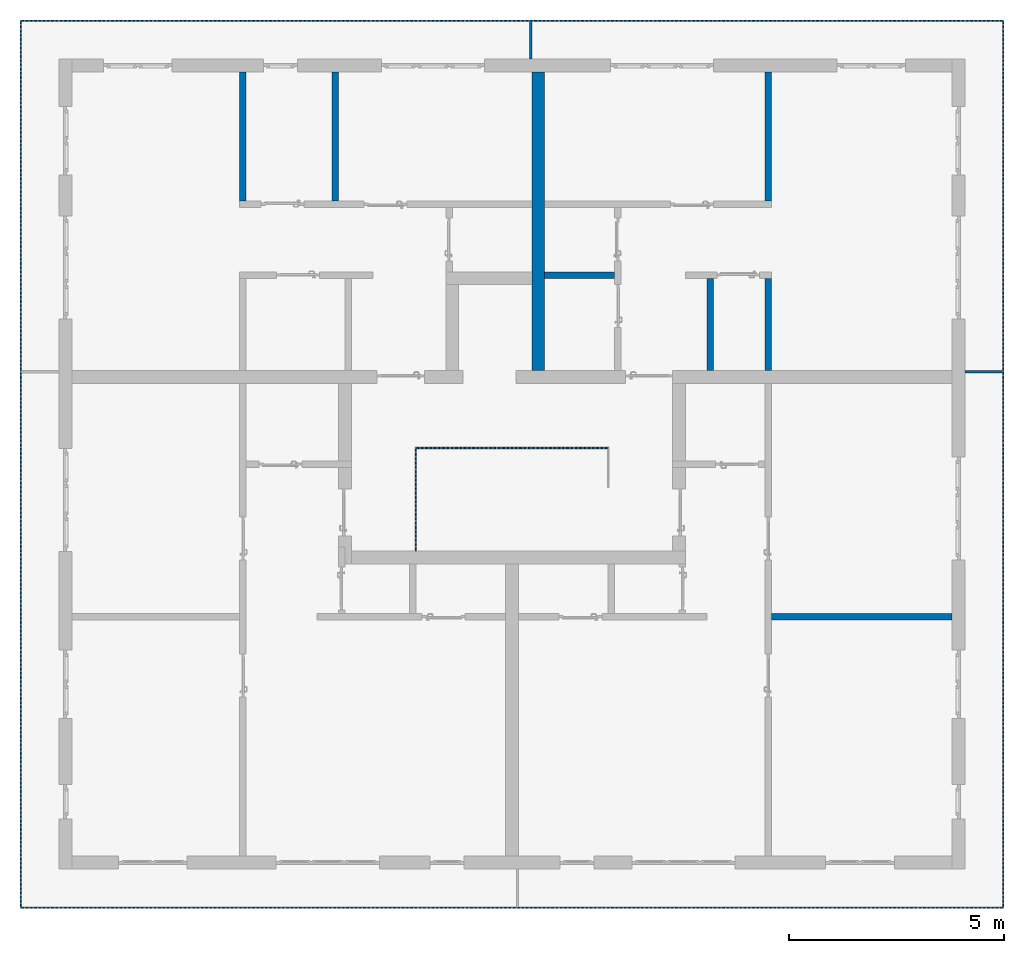
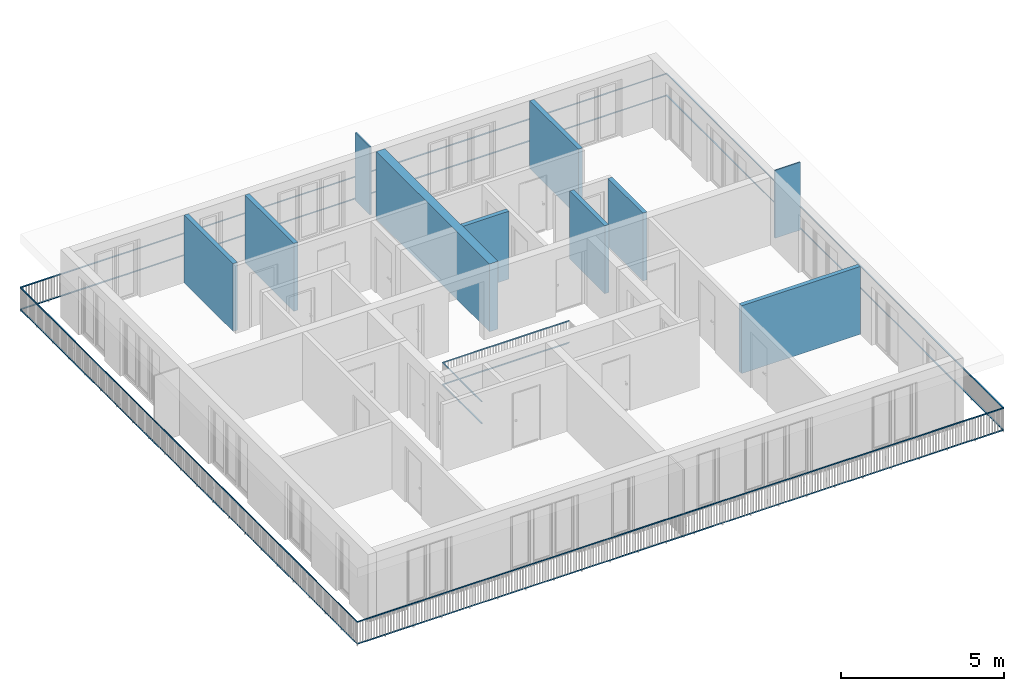
# One storey, part 31 of 54: 12 building element parts, 10 walls, 2 elements without a shape of their own.
"""IFC4 building model written with IfcOpenShell, lengths in metres."""

from ifc_helpers import new_model, entity, si_unit, converted_unit, derived_unit, direction, frame, origin_with_axes, place, context, subcontext, project, spatial, polygons, material, type_object, element, aggregate, save


model = new_model("IFC4")

# Units and contexts
model_context = context("Model", 3, precision=1e-05, world=origin_with_axes(), true_north=direction((0.0, 1.0)))
body_context = subcontext(model_context, "Body", "Model", "MODEL_VIEW")
ifc_project = project(units=[si_unit("LENGTHUNIT", "METRE"), si_unit("AREAUNIT", "SQUARE_METRE"), si_unit("VOLUMEUNIT", "CUBIC_METRE"), converted_unit("PLANEANGLEUNIT", "DEGREE", entity("IfcPlaneAngleMeasure", 0.0174532925199), si_unit("PLANEANGLEUNIT", "RADIAN"), dimensions=[0, 0, 0, 0, 0, 0, 0]), converted_unit("TIMEUNIT", "Year", entity("IfcTimeMeasure", 31556926.0), si_unit("TIMEUNIT", "SECOND"), dimensions=[0, 0, 1, 0, 0, 0, 0]), si_unit("MASSUNIT", "GRAM", prefix="KILO"), si_unit("THERMODYNAMICTEMPERATUREUNIT", "DEGREE_CELSIUS"), si_unit("LUMINOUSINTENSITYUNIT", "LUMEN"), si_unit("ENERGYUNIT", "JOULE", prefix="MEGA"), derived_unit("THERMALCONDUCTANCEUNIT", [(si_unit("POWERUNIT", "WATT"), 1), (si_unit("LENGTHUNIT", "METRE"), -1), (si_unit("THERMODYNAMICTEMPERATUREUNIT", "KELVIN"), -1)]), derived_unit("SPECIFICHEATCAPACITYUNIT", [(si_unit("ENERGYUNIT", "JOULE"), 1), (si_unit("MASSUNIT", "GRAM", prefix="KILO"), -1), (si_unit("THERMODYNAMICTEMPERATUREUNIT", "KELVIN"), -1)]), derived_unit("MASSDENSITYUNIT", [(si_unit("MASSUNIT", "GRAM", prefix="KILO"), 1), (si_unit("VOLUMEUNIT", "CUBIC_METRE"), -1)])], contexts=[model_context])

# Site, building, storey
site_placement = place(None, origin_with_axes())
site = spatial("IfcSite", under=ifc_project, at=site_placement, CompositionType="ELEMENT")
building_placement = place(site_placement, origin_with_axes())
building = spatial("IfcBuilding", under=site, at=building_placement, CompositionType="ELEMENT")
storey_placement = place(building_placement, frame((0.0, 0.0, 9.18), z_axis=(0.0, 0.0, 1.0), x_axis=(1.0, 0.0, 0.0)))
storey = spatial("IfcBuildingStorey", under=building, at=storey_placement, Name="3. Geschoss", CompositionType="ELEMENT", Elevation=9.18)

# Walls
ifc_material_1 = material()
wall_type_1 = type_object("IfcWallType", Name="300", PredefinedType="NOTDEFINED")
wall_1_placement = place(storey_placement, frame((-0.742199380397, 1.37118776896, 0.0), z_axis=(0.0, 0.0, 1.0), x_axis=(0.0, 1.0, 0.0)))
element("IfcWall", 1, at=wall_1_placement, inside=storey, type_object=wall_type_1, material=ifc_material_1, Name="Wand-001", PredefinedType="NOTDEFINED", context=body_context, shape_type="Tessellation", body=[
    polygons([(7.25, 0.0, 0.0), (7.25, 0.0, 2.54), (7.25, -0.3, 2.54), (7.25, -0.3, 0.0), (0.3, 0.0, 0.0), (0.3, 0.0, 2.54), (0.3, -0.3, 2.54), (0.3, -0.3, 0.0)], [[[1, 2, 3, 4]], [[5, 6, 2, 1]], [[6, 7, 3, 2]], [[4, 3, 7, 8]], [[8, 5, 1, 4]], [[8, 7, 6, 5]]], closed=True),
])
wall_type_2 = type_object("IfcWallType", Name="150", PredefinedType="NOTDEFINED")
wall_2_placement = place(storey_placement, frame((-7.5421993804, 5.47118776896, 0.0), z_axis=(0.0, 0.0, 1.0), x_axis=(0.0, 1.0, 0.0)))
element("IfcWall", 2, at=wall_2_placement, inside=storey, type_object=wall_type_2, material=ifc_material_1, Name="Wand-002", PredefinedType="NOTDEFINED", context=body_context, shape_type="Tessellation", body=[
    polygons([(3.15, 0.0, 0.0), (3.15, 0.0, 2.54), (3.15, -0.15, 2.54), (3.15, -0.15, 0.0), (0.15, 0.0, 0.0), (0.15, 0.0, 2.54), (0.15, -0.15, 2.54), (0.15, -0.15, 0.0)], [[[1, 2, 3, 4]], [[5, 6, 2, 1]], [[6, 7, 3, 2]], [[4, 3, 7, 8]], [[5, 1, 4, 8]], [[8, 7, 6, 5]]], closed=True),
])
wall_3_placement = place(storey_placement, frame((3.3378006196, 1.37118776896, 0.0), z_axis=(0.0, 0.0, 1.0), x_axis=(0.0, 1.0, 0.0)))
element("IfcWall", 3, at=wall_3_placement, inside=storey, type_object=wall_type_2, material=ifc_material_1, Name="Wand-002", PredefinedType="NOTDEFINED", context=body_context, shape_type="Tessellation", body=[
    polygons([(2.45, 0.0, 0.0), (2.45, 0.0, 2.54), (2.45, -0.15, 2.54), (2.45, -0.15, 0.0), (0.3, 0.0, 0.0), (0.3, 0.0, 2.54), (0.3, -0.15, 2.54), (0.3, -0.15, 0.0)], [[[1, 2, 3, 4]], [[5, 6, 2, 1]], [[6, 7, 3, 2]], [[4, 3, 7, 8]], [[5, 1, 4, 8]], [[8, 7, 6, 5]]], closed=True),
])
wall_4_placement = place(storey_placement, frame((1.3378006196, 3.97118776896, 0.0), z_axis=(0.0, 0.0, 1.0), x_axis=(-1.0, 0.0, 0.0)))
element("IfcWall", 4, at=wall_4_placement, inside=storey, type_object=wall_type_2, material=ifc_material_1, Name="Wand-002", PredefinedType="NOTDEFINED", context=body_context, shape_type="Tessellation", body=[
    polygons([(1.78, 0.0, 0.0), (1.78, 0.0, 2.54), (0.15, 0.0, 2.54), (0.15, 0.0, 0.0), (1.78, 0.15, 0.0), (1.78, 0.15, 2.54), (0.15, 0.15, 2.54), (0.15, 0.15, 0.0)], [[[1, 2, 3, 4]], [[5, 6, 2, 1]], [[6, 7, 3, 2]], [[4, 3, 7, 8]], [[8, 5, 1, 4]], [[8, 7, 6, 5]]], closed=True),
])
for number, where, z_axis, x_axis, name in (
    (5, (-5.3921993804, 5.47118776896, 0.0), (0.0, 0.0, 1.0), (0.0, 1.0, 0.0), "Wand-002"),
    (6, (4.6878006196, 5.47118776896, 0.0), (0.0, 0.0, 1.0), (0.0, 1.0, 0.0), "Wand-002"),
):
    element("IfcWall", number, at=place(storey_placement, frame(where, z_axis=z_axis, x_axis=x_axis)), inside=storey, type_object=wall_type_2, material=ifc_material_1, Name=name, PredefinedType="NOTDEFINED", context=body_context, shape_type="Tessellation", body=[
        polygons([(3.15, 0.0, 0.0), (3.15, 0.0, 2.54), (3.15, -0.15, 2.54), (3.15, -0.15, 0.0), (0.15, 0.0, 0.0), (0.15, 0.0, 2.54), (0.15, -0.15, 2.54), (0.15, -0.15, 0.0)], [[[1, 2, 3, 4]], [[5, 6, 2, 1]], [[6, 7, 3, 2]], [[4, 3, 7, 8]], [[5, 1, 4, 8]], [[8, 7, 6, 5]]], closed=True),
    ])
wall_5_placement = place(storey_placement, frame((9.3378006196, -4.12881223104, 0.0), z_axis=(0.0, 0.0, 1.0), x_axis=(-1.0, 0.0, 0.0)))
element("IfcWall", 7, at=wall_5_placement, inside=storey, type_object=wall_type_2, material=ifc_material_1, Name="Wand-004", PredefinedType="NOTDEFINED", context=body_context, shape_type="Tessellation", body=[
    polygons([(4.5, -0.15, 0.0), (4.5, -0.15, 2.54), (0.3, -0.15, 2.54), (0.3, -0.15, 0.0), (4.5, 0.0, 0.0), (4.5, 0.0, 2.54), (0.3, 0.0, 2.54), (0.3, 0.0, 0.0)], [[[1, 2, 3, 4]], [[5, 6, 2, 1]], [[6, 7, 3, 2]], [[4, 3, 7, 8]], [[8, 5, 1, 4]], [[8, 7, 6, 5]]], closed=True),
])
wall_6_placement = place(storey_placement, frame((4.6878006196, 1.37118776896, 0.0), z_axis=(0.0, 0.0, 1.0), x_axis=(0.0, 1.0, 0.0)))
element("IfcWall", 8, at=wall_6_placement, inside=storey, type_object=wall_type_2, material=ifc_material_1, Name="Wand-002", PredefinedType="NOTDEFINED", context=body_context, shape_type="Tessellation", body=[
    polygons([(2.45, 0.0, 0.0), (2.45, 0.0, 2.54), (2.45, -0.15, 2.54), (2.45, -0.15, 0.0), (0.3, 0.0, 0.0), (0.3, 0.0, 2.54), (0.3, -0.15, 2.54), (0.3, -0.15, 0.0)], [[[1, 2, 3, 4]], [[5, 6, 2, 1]], [[6, 7, 3, 2]], [[4, 3, 7, 8]], [[5, 1, 4, 8]], [[8, 7, 6, 5]]], closed=True),
])
ifc_material_2 = material()
wall_type_3 = type_object("IfcWallType", Name="50", PredefinedType="NOTDEFINED")
wall_7_placement = place(storey_placement, frame((9.0378006196, 1.67118776896, 0.0), z_axis=(0.0, 0.0, 1.0), x_axis=(1.0, 0.0, 0.0)))
element("IfcWall", 9, at=wall_7_placement, inside=storey, type_object=wall_type_3, material=ifc_material_2, Name="Wand-003", PredefinedType="NOTDEFINED", context=body_context, shape_type="Tessellation", body=[
    polygons([(0.3, 0.0, 2.54), (1.2, 0.0, 2.54), (1.2, 0.0, 0.0), (0.3, 0.0, 0.0), (1.2, -0.05, 2.54), (0.3, -0.05, 2.54), (1.2, -0.05, 0.0), (0.3, -0.05, 0.0)], [[[1, 2, 3, 4]], [[5, 2, 1, 6]], [[2, 5, 7, 3]], [[4, 3, 7, 8]], [[6, 1, 4, 8]], [[5, 6, 8, 7]]], closed=True),
])
wall_8_placement = place(storey_placement, frame((-0.742199380397, 9.82118776896, 0.0), z_axis=(0.0, 0.0, 1.0), x_axis=(0.0, -1.0, 0.0)))
element("IfcWall", 10, at=wall_8_placement, inside=storey, type_object=wall_type_3, material=ifc_material_2, Name="Wand-003", PredefinedType="NOTDEFINED", context=body_context, shape_type="Tessellation", body=[
    polygons([(0.0, -0.05, 2.54), (0.0, 0.0, 2.54), (0.0, 0.0, 0.0), (0.0, -0.05, 0.0), (0.9, 0.0, 2.54), (0.9, -0.05, 2.54), (0.9, 0.0, 0.0), (0.9, -0.05, 0.0)], [[[1, 2, 3, 4]], [[5, 2, 1, 6]], [[2, 5, 7, 3]], [[7, 8, 4, 3]], [[6, 1, 4, 8]], [[5, 6, 8, 7]]], closed=True),
])

# Space
space_1_placement = place(storey_placement, frame((-3.4421993804, -2.52881223104, 0.0), z_axis=(0.0, 0.0, 1.0), x_axis=(1.0, 0.0, 0.0)))
space_1 = spatial("IfcSpace", under=storey, at=space_1_placement, CompositionType="ELEMENT", PredefinedType="INTERNAL")

# Railing, building element parts
railing_type = type_object("IfcRailingType", PredefinedType="NOTDEFINED")
railing_1_placement = place(space_1_placement, frame((0.0, 1.5, 0.0), z_axis=(0.0, 0.0, 1.0), x_axis=(1.0, 0.0, 0.0)))
railing_1 = element("IfcRailing", 11, at=railing_1_placement, inside=space_1, type_object=railing_type, PredefinedType="NOTDEFINED")
ifc_material_3 = material()
building_element_part_1_placement = place(railing_1_placement, origin_with_axes())
building_element_part_1 = element("IfcBuildingElementPart", 12, at=building_element_part_1_placement, material=ifc_material_3, PredefinedType="NOTDEFINED", context=body_context, shape_type="Tessellation", body=[
    polygons([(0.0125, -1.5, 0.9), (0.0125, -1.5, 0.875), (0.0125, 0.8875, 0.875), (0.0125, 0.8875, 0.9), (-0.0125, -1.5, 0.9), (-0.0125, -1.5, 0.875), (-0.0125, 0.9125, 0.875), (-0.0125, 0.9125, 0.9)], [[[1, 2, 3, 4]], [[1, 5, 6, 2]], [[2, 6, 7, 3]], [[4, 3, 7, 8]], [[5, 1, 4, 8]], [[6, 5, 8, 7]]], closed=True),
])
building_element_part_2_placement = place(railing_1_placement, origin_with_axes())
building_element_part_2 = element("IfcBuildingElementPart", 13, at=building_element_part_2_placement, material=ifc_material_3, PredefinedType="NOTDEFINED", context=body_context, shape_type="Tessellation", body=[
    polygons([(0.0125, -1.5, 0.0825), (0.0125, -1.5, 0.0575), (0.0125, 0.8875, 0.0575), (0.0125, 0.8875, 0.0825), (-0.0125, -1.5, 0.0825), (-0.0125, -1.5, 0.0575), (-0.0125, 0.9125, 0.0575), (-0.0125, 0.9125, 0.0825)], [[[1, 2, 3, 4]], [[1, 5, 6, 2]], [[2, 6, 7, 3]], [[4, 3, 7, 8]], [[5, 1, 4, 8]], [[6, 5, 8, 7]]], closed=True),
])
building_element_part_3_placement = place(railing_1_placement, origin_with_axes())
building_element_part_3 = element("IfcBuildingElementPart", 14, at=building_element_part_3_placement, material=ifc_material_3, PredefinedType="NOTDEFINED", context=body_context, shape_type="Tessellation", body=[
    polygons([(0.0125, 0.8875, 0.9), (0.0125, 0.8875, 0.875), (4.4675, 0.8875, 0.875), (4.4675, 0.8875, 0.9), (-0.0125, 0.9125, 0.9), (-0.0125, 0.9125, 0.875), (4.4925, 0.9125, 0.875), (4.4925, 0.9125, 0.9)], [[[1, 2, 3, 4]], [[1, 5, 6, 2]], [[2, 6, 7, 3]], [[4, 3, 7, 8]], [[5, 1, 4, 8]], [[6, 5, 8, 7]]], closed=True),
])
building_element_part_4_placement = place(railing_1_placement, origin_with_axes())
building_element_part_4 = element("IfcBuildingElementPart", 15, at=building_element_part_4_placement, material=ifc_material_3, PredefinedType="NOTDEFINED", context=body_context, shape_type="Tessellation", body=[
    polygons([(0.0125, 0.8875, 0.0825), (0.0125, 0.8875, 0.0575), (4.4675, 0.8875, 0.0575), (4.4675, 0.8875, 0.0825), (-0.0125, 0.9125, 0.0825), (-0.0125, 0.9125, 0.0575), (4.4925, 0.9125, 0.0575), (4.4925, 0.9125, 0.0825)], [[[1, 2, 3, 4]], [[1, 5, 6, 2]], [[2, 6, 7, 3]], [[4, 3, 7, 8]], [[5, 1, 4, 8]], [[6, 5, 8, 7]]], closed=True),
])
aggregate(railing_1, [building_element_part_1, building_element_part_2, building_element_part_3, building_element_part_4])

# Space
space_2_placement = place(storey_placement, frame((10.2378006196, 9.82118769833, 0.0), z_axis=(0.0, 0.0, 1.0), x_axis=(-1.0, 0.0, 0.0)))
space_2 = spatial("IfcSpace", under=storey, at=space_2_placement, CompositionType="ELEMENT", PredefinedType="EXTERNAL")

# Railing, building element parts
railing_2_placement = place(space_2_placement, frame((0.0, -7.06315681498e-08, 0.0), z_axis=(0.0, 0.0, 1.0), x_axis=(-1.0, 0.0, 0.0)))
railing_2 = element("IfcRailing", 16, at=railing_2_placement, inside=space_2, type_object=railing_type, PredefinedType="NOTDEFINED")
building_element_part_5_placement = place(railing_2_placement, origin_with_axes())
building_element_part_5 = element("IfcBuildingElementPart", 17, at=building_element_part_5_placement, material=ifc_material_3, PredefinedType="NOTDEFINED", context=body_context, shape_type="Tessellation", body=[
    polygons([(0.0, 0.0125, 0.9), (0.0, 0.0125, 0.875), (-22.8925, 0.0125, 0.875), (-22.8925, 0.0125, 0.9), (0.0, -0.0125, 0.9), (0.0, -0.0125, 0.875), (-22.8675, -0.0125, 0.875), (-22.8675, -0.0125, 0.9)], [[[1, 2, 3, 4]], [[1, 5, 6, 2]], [[2, 6, 7, 3]], [[4, 3, 7, 8]], [[5, 1, 4, 8]], [[6, 5, 8, 7]]], closed=True),
])
building_element_part_6_placement = place(railing_2_placement, origin_with_axes())
building_element_part_6 = element("IfcBuildingElementPart", 18, at=building_element_part_6_placement, material=ifc_material_3, PredefinedType="NOTDEFINED", context=body_context, shape_type="Tessellation", body=[
    polygons([(0.0, 0.0125, 0.0825), (0.0, 0.0125, 0.0575), (-22.8925, 0.0125, 0.0575), (-22.8925, 0.0125, 0.0825), (0.0, -0.0125, 0.0825), (0.0, -0.0125, 0.0575), (-22.8675, -0.0125, 0.0575), (-22.8675, -0.0125, 0.0825)], [[[1, 2, 3, 4]], [[1, 5, 6, 2]], [[2, 6, 7, 3]], [[4, 3, 7, 8]], [[5, 1, 4, 8]], [[6, 5, 8, 7]]], closed=True),
])
building_element_part_7_placement = place(railing_2_placement, origin_with_axes())
building_element_part_7 = element("IfcBuildingElementPart", 19, at=building_element_part_7_placement, material=ifc_material_3, PredefinedType="NOTDEFINED", context=body_context, shape_type="Tessellation", body=[
    polygons([(-22.8925, 0.0125, 0.9), (-22.8925, 0.0125, 0.875), (-22.8925, -20.6625, 0.875), (-22.8925, -20.6625, 0.9), (-22.8675, -0.0125, 0.9), (-22.8675, -0.0125, 0.875), (-22.8675, -20.6375, 0.875), (-22.8675, -20.6375, 0.9)], [[[1, 2, 3, 4]], [[1, 5, 6, 2]], [[2, 6, 7, 3]], [[4, 3, 7, 8]], [[5, 1, 4, 8]], [[6, 5, 8, 7]]], closed=True),
])
building_element_part_8_placement = place(railing_2_placement, origin_with_axes())
building_element_part_8 = element("IfcBuildingElementPart", 20, at=building_element_part_8_placement, material=ifc_material_3, PredefinedType="NOTDEFINED", context=body_context, shape_type="Tessellation", body=[
    polygons([(-22.8925, 0.0125, 0.0825), (-22.8925, 0.0125, 0.0575), (-22.8925, -20.6625, 0.0575), (-22.8925, -20.6625, 0.0825), (-22.8675, -0.0125, 0.0825), (-22.8675, -0.0125, 0.0575), (-22.8675, -20.6375, 0.0575), (-22.8675, -20.6375, 0.0825)], [[[1, 2, 3, 4]], [[1, 5, 6, 2]], [[2, 6, 7, 3]], [[4, 3, 7, 8]], [[5, 1, 4, 8]], [[6, 5, 8, 7]]], closed=True),
])
building_element_part_9_placement = place(railing_2_placement, origin_with_axes())
building_element_part_9 = element("IfcBuildingElementPart", 21, at=building_element_part_9_placement, material=ifc_material_3, PredefinedType="NOTDEFINED", context=body_context, shape_type="Tessellation", body=[
    polygons([(-22.8925, -20.6625, 0.9), (-22.8925, -20.6625, 0.875), (0.0125, -20.6625, 0.875), (0.0125, -20.6625, 0.9), (-22.8675, -20.6375, 0.9), (-22.8675, -20.6375, 0.875), (-0.0125, -20.6375, 0.875), (-0.0125, -20.6375, 0.9)], [[[1, 2, 3, 4]], [[1, 5, 6, 2]], [[2, 6, 7, 3]], [[4, 3, 7, 8]], [[5, 1, 4, 8]], [[6, 5, 8, 7]]], closed=True),
])
building_element_part_10_placement = place(railing_2_placement, origin_with_axes())
building_element_part_10 = element("IfcBuildingElementPart", 22, at=building_element_part_10_placement, material=ifc_material_3, PredefinedType="NOTDEFINED", context=body_context, shape_type="Tessellation", body=[
    polygons([(-22.8925, -20.6625, 0.0825), (-22.8925, -20.6625, 0.0575), (0.0125, -20.6625, 0.0575), (0.0125, -20.6625, 0.0825), (-22.8675, -20.6375, 0.0825), (-22.8675, -20.6375, 0.0575), (-0.0125, -20.6375, 0.0575), (-0.0125, -20.6375, 0.0825)], [[[1, 2, 3, 4]], [[1, 5, 6, 2]], [[2, 6, 7, 3]], [[4, 3, 7, 8]], [[5, 1, 4, 8]], [[6, 5, 8, 7]]], closed=True),
])
building_element_part_11_placement = place(railing_2_placement, origin_with_axes())
building_element_part_11 = element("IfcBuildingElementPart", 23, at=building_element_part_11_placement, material=ifc_material_3, PredefinedType="NOTDEFINED", context=body_context, shape_type="Tessellation", body=[
    polygons([(0.0125, -20.6625, 0.9), (0.0125, -20.6625, 0.875), (0.0125, 0.0, 0.875), (0.0125, 0.0, 0.9), (-0.0125, -20.6375, 0.9), (-0.0125, -20.6375, 0.875), (-0.0125, 0.0, 0.875), (-0.0125, 0.0, 0.9)], [[[1, 2, 3, 4]], [[1, 5, 6, 2]], [[2, 6, 7, 3]], [[4, 3, 7, 8]], [[5, 1, 4, 8]], [[6, 5, 8, 7]]], closed=True),
])
building_element_part_12_placement = place(railing_2_placement, origin_with_axes())
building_element_part_12 = element("IfcBuildingElementPart", 24, at=building_element_part_12_placement, material=ifc_material_3, PredefinedType="NOTDEFINED", context=body_context, shape_type="Tessellation", body=[
    polygons([(0.0125, -20.6625, 0.0825), (0.0125, -20.6625, 0.0575), (0.0125, 0.0, 0.0575), (0.0125, 0.0, 0.0825), (-0.0125, -20.6375, 0.0825), (-0.0125, -20.6375, 0.0575), (-0.0125, 0.0, 0.0575), (-0.0125, 0.0, 0.0825)], [[[1, 2, 3, 4]], [[1, 5, 6, 2]], [[2, 6, 7, 3]], [[4, 3, 7, 8]], [[5, 1, 4, 8]], [[6, 5, 8, 7]]], closed=True),
])
aggregate(railing_2, [building_element_part_5, building_element_part_6, building_element_part_7, building_element_part_8, building_element_part_9, building_element_part_10, building_element_part_11, building_element_part_12])

save(model, "model.ifc")
